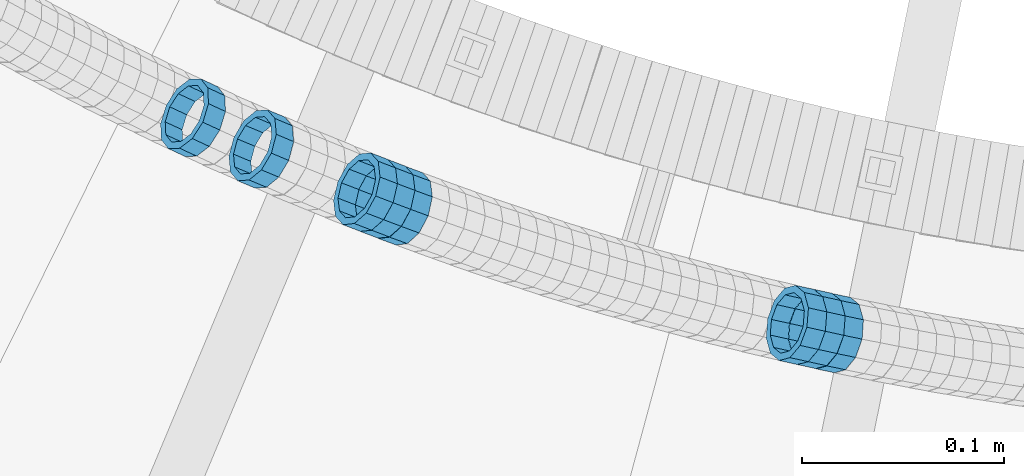
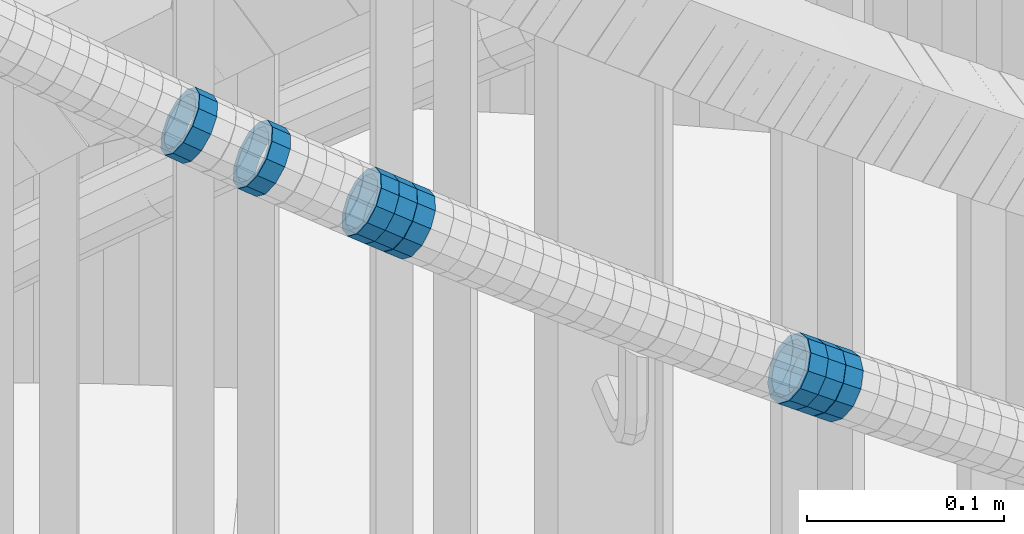
# One storey, part 690 of 975: 8 members.
"""IFC2X3 building model written with IfcOpenShell, lengths in millimetres."""

from ifc_helpers import new_model, si_unit, frame, origin_with_axes, place, context, subcontext, project, spatial, faceted_brep, material, type_object, element, save


model = new_model("IFC2X3")

# Units and contexts
model_context = context("Model", 3, precision=1e-05, world=origin_with_axes())
body_context = subcontext(model_context, "Body", "Model", "MODEL_VIEW")
ifc_project = project(units=[si_unit("LENGTHUNIT", "METRE", prefix="MILLI"), si_unit("AREAUNIT", "SQUARE_METRE"), si_unit("VOLUMEUNIT", "CUBIC_METRE"), si_unit("MASSUNIT", "GRAM", prefix="KILO"), si_unit("TIMEUNIT", "SECOND"), si_unit("PLANEANGLEUNIT", "RADIAN"), si_unit("SOLIDANGLEUNIT", "STERADIAN"), si_unit("THERMODYNAMICTEMPERATUREUNIT", "DEGREE_CELSIUS"), si_unit("LUMINOUSINTENSITYUNIT", "LUMEN")], contexts=[model_context])

# Site, building, storey
site_placement = place(None, origin_with_axes())
site = spatial("IfcSite", under=ifc_project, at=site_placement, CompositionType="ELEMENT")
building_placement = place(site_placement, origin_with_axes())
building = spatial("IfcBuilding", under=site, at=building_placement, Name="Undefined", CompositionType="ELEMENT")
storey_placement = place(building_placement, origin_with_axes())
storey = spatial("IfcBuildingStorey", under=building, at=storey_placement, Name="Undefined", CompositionType="ELEMENT", Elevation=0.0)

# Members
ifc_material = material()
member_type = type_object("IfcMemberType", PredefinedType="NOTDEFINED")
member_1_placement = place(storey_placement, frame((34111.9400703287, 2061.41221521128, 4603.27653014388), z_axis=(-0.421111305950152, -0.907008967982653, -2.33285391004756e-11), x_axis=(-0.772432162974073, 0.358629217987961, 0.524150395982431)))
element("IfcMember", 1, at=member_1_placement, inside=storey, type_object=member_type, material=ifc_material, Name="WALL", context=body_context, shape_type="Brep", body=[
    faceted_brep([(-2.1246523829177e-07, -15.367000000002, 0.0), (-1.83998054126278e-07, -13.3082123799541, 7.68350000000009), (10.8747413762467, -13.3082123799468, 7.68349999999737), (10.8747413762612, -15.3669999999911, -4.54747350886464e-12), (-1.06232619145885e-07, -7.68349999999919, 13.3082123799559), (10.8747413762321, -7.68350000000282, 13.3082123799559), (-3.63797880709171e-12, 3.63797880709171e-12, 15.3670000000002), (10.8747413762212, -7.27595761418343e-12, 15.3670000000029), (1.06225343188271e-07, 7.68350000000646, 13.3082123799559), (10.8747413762139, 7.68349999998827, 13.3082123799586), (1.8399441614747e-07, 13.308212379965, 7.68350000000009), (10.8747413762212, 13.3082123799504, 7.683500000001), (2.12461600312963e-07, 15.3670000000093, 0.0), (10.8747413762285, 15.3669999999984, 9.09494701772928e-13), (1.8399441614747e-07, 13.308212379965, -7.68350000000009), (10.8747413762394, 13.3082123799613, -7.683500000001), (1.06225343188271e-07, 7.68350000000646, -13.3082123799559), (10.874741376254, 7.68350000001374, -13.3082123799604), (-3.63797880709171e-12, 3.63797880709171e-12, -15.3670000000002), (10.8747413762685, 1.81898940354586e-11, -15.3670000000056), (-1.06232619145885e-07, -7.68349999999919, -13.3082123799559), (10.8747413762758, -7.683499999981, -13.3082123799632), (-1.83998054126278e-07, -13.3082123799541, -7.68350000000009), (10.8747413762721, -13.3082123799359, -7.68350000000737), (-2.63386027654633e-07, -19.0500000000029, 0.0), (-2.28097633225843e-07, -16.4977839420972, -9.52499999999964), (10.8747413762867, -16.4977839420681, -9.52500000000873), (10.8747413762685, -19.0499999999847, -6.3664629124105e-12), (-1.31691194837913e-07, -9.52500000000146, -16.4977839420935), (10.8747413762831, -9.52499999997599, -16.4977839421026), (-3.63797880709171e-12, 3.63797880709171e-12, -19.0500000000002), (10.8747413762758, 2.5465851649642e-11, -19.0500000000084), (1.31687556859106e-07, 9.52500000000509, -16.4977839420935), (10.8747413762612, 9.52500000001601, -16.497783942099), (2.28097633225843e-07, 16.4977839421044, -9.52499999999964), (10.8747413762394, 16.4977839421008, -9.52500000000146), (2.63382389675826e-07, 19.0500000000138, 0.0), (10.8747413762248, 19.0499999999956, 0.0), (2.28097633225843e-07, 16.4977839421044, 9.52499999999964), (10.8747413762103, 16.497783942079, 9.52500000000418), (1.31687556859106e-07, 9.52500000000509, 16.4977839420935), (10.8747413762067, 9.52499999998327, 16.4977839420981), (-3.63797880709171e-12, 3.63797880709171e-12, 19.0500000000002), (10.8747413762212, -1.09139364212751e-11, 19.0500000000029), (-1.31691194837913e-07, -9.52500000000146, 16.4977839420935), (10.8747413762358, -9.52500000000146, 16.4977839420944), (-2.28097633225843e-07, -16.4977839420972, 9.52499999999964), (10.874741376254, -16.4977839420862, 9.524999999996)], [[[0, 1, 2, 3]], [[1, 4, 5, 2]], [[4, 6, 7, 5]], [[6, 8, 9, 7]], [[8, 10, 11, 9]], [[10, 12, 13, 11]], [[12, 14, 15, 13]], [[14, 16, 17, 15]], [[16, 18, 19, 17]], [[18, 20, 21, 19]], [[20, 22, 23, 21]], [[22, 0, 3, 23]], [[24, 25, 26, 27]], [[25, 28, 29, 26]], [[28, 30, 31, 29]], [[30, 32, 33, 31]], [[32, 34, 35, 33]], [[34, 36, 37, 35]], [[36, 38, 39, 37]], [[38, 40, 41, 39]], [[40, 42, 43, 41]], [[42, 44, 45, 43]], [[44, 46, 47, 45]], [[46, 24, 27, 47]], [[29, 31, 33, 35, 37, 39, 41, 43, 45, 47, 27, 26], [5, 7, 9, 11, 13, 15, 17, 19, 21, 23, 3, 2]], [[46, 44, 42, 40, 38, 36, 34, 32, 30, 28, 25, 24], [22, 20, 18, 16, 14, 12, 10, 8, 6, 4, 1, 0]]]),
])
member_2_placement = place(storey_placement, frame((34419.763839228, 1957.86844079665, 4402.52752626704), z_axis=(-0.214657030653907, -0.976689489649012, -1.63522599905264e-10), x_axis=(-0.829159326808045, 0.182232818957796, 0.528475174877615)))
element("IfcMember", 2, at=member_2_placement, inside=storey, type_object=member_type, material=ifc_material, Name="WALL", context=body_context, shape_type="Brep", body=[
    faceted_brep([(-2.1246523829177e-07, -15.367000000002, 0.0), (-1.83998054126278e-07, -13.3082123799541, 7.68350000000009), (10.9726933794955, -13.3082123799577, 7.68349999999873), (10.9726933795027, -15.3669999999984, -3.18323145620525e-12), (-1.06232619145885e-07, -7.68349999999919, 13.3082123799559), (10.9726933794846, -7.6835000000101, 13.308212379955), (-3.63797880709171e-12, 3.63797880709171e-12, 15.3670000000002), (10.9726933794773, -1.09139364212751e-11, 15.3670000000011), (1.06225343188271e-07, 7.68350000000646, 13.3082123799559), (10.9726933794773, 7.68349999998827, 13.3082123799563), (1.8399441614747e-07, 13.308212379965, 7.68350000000009), (10.9726933794846, 13.3082123799504, 7.68350000000146), (2.12461600312963e-07, 15.3670000000093, 0.0), (10.9726933794882, 15.3669999999984, 9.09494701772928e-13), (1.8399441614747e-07, 13.308212379965, -7.68350000000009), (10.9726933794955, 13.3082123799613, -7.68350000000055), (1.06225343188271e-07, 7.68350000000646, -13.3082123799559), (10.97269337951, 7.68350000001374, -13.3082123799572), (-3.63797880709171e-12, 3.63797880709171e-12, -15.3670000000002), (10.97269337951, 1.09139364212751e-11, -15.3670000000029), (-1.06232619145885e-07, -7.68349999999919, -13.3082123799559), (10.9726933795137, -7.68349999998463, -13.3082123799586), (-1.83998054126278e-07, -13.3082123799541, -7.68350000000009), (10.9726933795064, -13.3082123799468, -7.68350000000328), (-2.63386027654633e-07, -19.0500000000029, 0.0), (-2.28097633225843e-07, -16.4977839420972, -9.52499999999964), (10.97269337951, -16.4977839420826, -9.52500000000418), (10.9726933795027, -19.0499999999993, -2.27373675443232e-12), (-1.31691194837913e-07, -9.52500000000146, -16.4977839420935), (10.9726933795137, -9.52499999998327, -16.4977839420976), (-3.63797880709171e-12, 3.63797880709171e-12, -19.0500000000002), (10.9726933795209, 1.81898940354586e-11, -19.0500000000034), (1.31687556859106e-07, 9.52500000000509, -16.4977839420935), (10.97269337951, 9.52500000001237, -16.4977839420958), (2.28097633225843e-07, 16.4977839421044, -9.52499999999964), (10.9726933795027, 16.4977839421008, -9.525000000001), (2.63382389675826e-07, 19.0500000000138, 0.0), (10.9726933794882, 19.0499999999993, 4.54747350886464e-13), (2.28097633225843e-07, 16.4977839421044, 9.52499999999964), (10.9726933794809, 16.4977839420826, 9.52500000000236), (1.31687556859106e-07, 9.52500000000509, 16.4977839420935), (10.97269337947, 9.5249999999869, 16.4977839420967), (-3.63797880709171e-12, 3.63797880709171e-12, 19.0500000000002), (10.9726933794736, -1.81898940354586e-11, 19.0500000000015), (-1.31691194837913e-07, -9.52500000000146, 16.4977839420935), (10.9726933794809, -9.52500000001237, 16.4977839420931), (-2.28097633225843e-07, -16.4977839420972, 9.52499999999964), (10.9726933794882, -16.4977839420972, 9.52499999999827)], [[[0, 1, 2, 3]], [[1, 4, 5, 2]], [[4, 6, 7, 5]], [[6, 8, 9, 7]], [[8, 10, 11, 9]], [[10, 12, 13, 11]], [[12, 14, 15, 13]], [[14, 16, 17, 15]], [[16, 18, 19, 17]], [[18, 20, 21, 19]], [[20, 22, 23, 21]], [[22, 0, 3, 23]], [[24, 25, 26, 27]], [[25, 28, 29, 26]], [[28, 30, 31, 29]], [[30, 32, 33, 31]], [[32, 34, 35, 33]], [[34, 36, 37, 35]], [[36, 38, 39, 37]], [[38, 40, 41, 39]], [[40, 42, 43, 41]], [[42, 44, 45, 43]], [[44, 46, 47, 45]], [[46, 24, 27, 47]], [[29, 31, 33, 35, 37, 39, 41, 43, 45, 47, 27, 26], [5, 7, 9, 11, 13, 15, 17, 19, 21, 23, 3, 2]], [[46, 44, 42, 40, 38, 36, 34, 32, 30, 28, 25, 24], [22, 20, 18, 16, 14, 12, 10, 8, 6, 4, 1, 0]]]),
])
member_3_placement = place(storey_placement, frame((34428.9490765305, 1955.84259152865, 4396.75974216532), z_axis=(-0.204383799684052, -0.978890832742196, -1.57330759975593e-10), x_axis=(-0.834511263849983, 0.174238614968701, 0.522715845906064)))
element("IfcMember", 3, at=member_3_placement, inside=storey, type_object=member_type, material=ifc_material, Name="WALL", context=body_context, shape_type="Brep", body=[
    faceted_brep([(-2.1246523829177e-07, -15.367000000002, 0.0), (-1.83998054126278e-07, -13.3082123799541, 7.68350000000009), (10.9004587059244, -13.3082123799686, 7.68350000000282), (10.9004587059426, -15.3670000000093, 9.09494701772928e-13), (-1.06232619145885e-07, -7.68349999999919, 13.3082123799559), (10.9004587059244, -7.68350000001737, 13.3082123799586), (-3.63797880709171e-12, 3.63797880709171e-12, 15.3670000000002), (10.9004587059353, -1.45519152283669e-11, 15.3670000000029), (1.06225343188271e-07, 7.68350000000646, 13.3082123799559), (10.9004587059571, 7.68349999999555, 13.308212379955), (1.8399441614747e-07, 13.308212379965, 7.68350000000009), (10.9004587059753, 13.308212379965, 7.68349999999691), (2.12461600312963e-07, 15.3670000000093, 0.0), (10.9004587059935, 15.3670000000202, -5.45696821063757e-12), (1.8399441614747e-07, 13.308212379965, -7.68350000000009), (10.9004587060081, 13.3082123799832, -7.68350000000737), (1.06225343188271e-07, 7.68350000000646, -13.3082123799559), (10.9004587060081, 7.68350000002829, -13.3082123799632), (-3.63797880709171e-12, 3.63797880709171e-12, -15.3670000000002), (10.9004587060008, 2.91038304567337e-11, -15.3670000000075), (-1.06232619145885e-07, -7.68349999999919, -13.3082123799559), (10.900458705979, -7.683499999981, -13.3082123799595), (-1.83998054126278e-07, -13.3082123799541, -7.68350000000009), (10.9004587059608, -13.3082123799504, -7.68350000000191), (-2.63386027654633e-07, -19.0500000000029, 0.0), (-2.28097633225843e-07, -16.4977839420972, -9.52499999999964), (10.9004587059499, -16.4977839420899, -9.525000000001), (10.9004587059317, -19.0500000000102, 1.81898940354586e-12), (-1.31691194837913e-07, -9.52500000000146, -16.4977839420935), (10.9004587059826, -9.52499999997963, -16.497783942099), (-3.63797880709171e-12, 3.63797880709171e-12, -19.0500000000002), (10.9004587060008, 2.91038304567337e-11, -19.0500000000084), (1.31687556859106e-07, 9.52500000000509, -16.4977839420935), (10.900458706019, 9.52500000003783, -16.4977839421026), (2.28097633225843e-07, 16.4977839421044, -9.52499999999964), (10.900458706019, 16.4977839421263, -9.52500000000873), (2.63382389675826e-07, 19.0500000000138, 0.0), (10.9004587060044, 19.0500000000247, -6.82121026329696e-12), (2.28097633225843e-07, 16.4977839421044, 9.52499999999964), (10.9004587059826, 16.4977839421044, 9.52499999999736), (1.31687556859106e-07, 9.52500000000509, 16.4977839420935), (10.9004587059571, 9.52499999999418, 16.497783942094), (-3.63797880709171e-12, 3.63797880709171e-12, 19.0500000000002), (10.900458705928, -2.18278728425503e-11, 19.0500000000038), (-1.31691194837913e-07, -9.52500000000146, 16.4977839420935), (10.9004587059135, -9.52500000002328, 16.4977839420981), (-2.28097633225843e-07, -16.4977839420972, 9.52499999999964), (10.9004587059171, -16.4977839421153, 9.52500000000373)], [[[0, 1, 2, 3]], [[1, 4, 5, 2]], [[4, 6, 7, 5]], [[6, 8, 9, 7]], [[8, 10, 11, 9]], [[10, 12, 13, 11]], [[12, 14, 15, 13]], [[14, 16, 17, 15]], [[16, 18, 19, 17]], [[18, 20, 21, 19]], [[20, 22, 23, 21]], [[22, 0, 3, 23]], [[24, 25, 26, 27]], [[25, 28, 29, 26]], [[28, 30, 31, 29]], [[30, 32, 33, 31]], [[32, 34, 35, 33]], [[34, 36, 37, 35]], [[36, 38, 39, 37]], [[38, 40, 41, 39]], [[40, 42, 43, 41]], [[42, 44, 45, 43]], [[44, 46, 47, 45]], [[46, 24, 27, 47]], [[29, 31, 33, 35, 37, 39, 41, 43, 45, 47, 27, 26], [5, 7, 9, 11, 13, 15, 17, 19, 21, 23, 3, 2]], [[46, 44, 42, 40, 38, 36, 34, 32, 30, 28, 25, 24], [22, 20, 18, 16, 14, 12, 10, 8, 6, 4, 1, 0]]]),
])
member_4_placement = place(storey_placement, frame((34410.7869067973, 1959.84139297923, 4408.24976541374), z_axis=(-0.214657030653907, -0.976689489649012, -1.63522599905264e-10), x_axis=(-0.833146108987075, 0.183109034997161, 0.521860749991897)))
element("IfcMember", 4, at=member_4_placement, inside=storey, type_object=member_type, material=ifc_material, Name="WALL", context=body_context, shape_type="Brep", body=[
    faceted_brep([(-2.1246523829177e-07, -15.367000000002, 0.0), (-1.83998054126278e-07, -13.3082123799541, 7.68350000000009), (10.9242848735521, -13.3082123800159, 7.68350000000919), (10.9242848735703, -15.3670000000457, 6.82121026329696e-12), (-1.06232619145885e-07, -7.68349999999919, 13.3082123799559), (10.9242848735521, -7.68350000005739, 13.3082123799652), (-3.63797880709171e-12, 3.63797880709171e-12, 15.3670000000002), (10.924284873563, -4.72937244921923e-11, 15.3670000000088), (1.06225343188271e-07, 7.68350000000646, 13.3082123799559), (10.9242848735885, 7.68349999997008, 13.308212379962), (1.8399441614747e-07, 13.308212379965, 7.68350000000009), (10.9242848736176, 13.3082123799468, 7.68350000000328), (2.12461600312963e-07, 15.3670000000093, 0.0), (10.9242848736394, 15.3670000000093, 0.0), (1.8399441614747e-07, 13.308212379965, -7.68350000000009), (10.9242848736576, 13.3082123799795, -7.6835000000026), (1.06225343188271e-07, 7.68350000000646, -13.3082123799559), (10.9242848736576, 7.68350000002465, -13.3082123799584), (-3.63797880709171e-12, 3.63797880709171e-12, -15.3670000000002), (10.9242848736467, 1.45519152283669e-11, -15.3670000000025), (-1.06232619145885e-07, -7.68349999999919, -13.3082123799559), (10.9242848736212, -7.68350000000282, -13.3082123799552), (-1.83998054126278e-07, -13.3082123799541, -7.68350000000009), (10.9242848735958, -13.3082123799832, -7.68349999999646), (-2.63386027654633e-07, -19.0500000000029, 0.0), (-2.28097633225843e-07, -16.4977839420972, -9.52499999999964), (10.9242848735885, -16.4977839421226, -9.52499999999577), (10.9242848735557, -19.0500000000575, 8.18545231595635e-12), (-1.31691194837913e-07, -9.52500000000146, -16.4977839420935), (10.9242848736249, -9.52500000000146, -16.4977839420942), (-3.63797880709171e-12, 3.63797880709171e-12, -19.0500000000002), (10.924284873654, 2.18278728425503e-11, -19.0500000000038), (1.31687556859106e-07, 9.52500000000509, -16.4977839420935), (10.9242848736758, 9.52500000003783, -16.4977839420985), (2.28097633225843e-07, 16.4977839421044, -9.52499999999964), (10.9242848736758, 16.4977839421299, -9.52500000000418), (2.63382389675826e-07, 19.0500000000138, 0.0), (10.9242848736503, 19.0500000000211, -1.36424205265939e-12), (2.28097633225843e-07, 16.4977839421044, 9.52499999999964), (10.9242848736249, 16.4977839420899, 9.52500000000259), (1.31687556859106e-07, 9.52500000000509, 16.4977839420935), (10.9242848735885, 9.52499999996508, 16.4977839421008), (-3.63797880709171e-12, 3.63797880709171e-12, 19.0500000000002), (10.9242848735594, -5.82076609134674e-11, 19.0500000000104), (-1.31691194837913e-07, -9.52500000000146, 16.4977839420935), (10.9242848735375, -9.52500000007058, 16.4977839421056), (-2.28097633225843e-07, -16.4977839420972, 9.52499999999964), (10.9242848735412, -16.4977839421626, 9.52500000001078)], [[[0, 1, 2, 3]], [[1, 4, 5, 2]], [[4, 6, 7, 5]], [[6, 8, 9, 7]], [[8, 10, 11, 9]], [[10, 12, 13, 11]], [[12, 14, 15, 13]], [[14, 16, 17, 15]], [[16, 18, 19, 17]], [[18, 20, 21, 19]], [[20, 22, 23, 21]], [[22, 0, 3, 23]], [[24, 25, 26, 27]], [[25, 28, 29, 26]], [[28, 30, 31, 29]], [[30, 32, 33, 31]], [[32, 34, 35, 33]], [[34, 36, 37, 35]], [[36, 38, 39, 37]], [[38, 40, 41, 39]], [[40, 42, 43, 41]], [[42, 44, 45, 43]], [[44, 46, 47, 45]], [[46, 24, 27, 47]], [[29, 31, 33, 35, 37, 39, 41, 43, 45, 47, 27, 26], [5, 7, 9, 11, 13, 15, 17, 19, 21, 23, 3, 2]], [[46, 44, 42, 40, 38, 36, 34, 32, 30, 28, 25, 24], [22, 20, 18, 16, 14, 12, 10, 8, 6, 4, 1, 0]]]),
])
member_5_placement = place(storey_placement, frame((34145.8142209841, 2046.09304426026, 4580.32466746783), z_axis=(-0.386138087857282, -0.922440988413851, -1.81316863745451e-10), x_axis=(-0.783243558288826, 0.327869396120886, 0.528234027194749)))
element("IfcMember", 5, at=member_5_placement, inside=storey, type_object=member_type, material=ifc_material, Name="WALL", context=body_context, shape_type="Brep", body=[
    faceted_brep([(-2.1246523829177e-07, -15.367000000002, 0.0), (-1.83998054126278e-07, -13.3082123799541, 7.68350000000009), (10.9799817850508, -13.3082123799686, 7.6835000000051), (10.9799817850435, -15.3670000000202, 5.45696821063757e-12), (-1.06232619145885e-07, -7.68349999999919, 13.3082123799559), (10.9799817850653, -7.68350000000282, 13.3082123799577), (-3.63797880709171e-12, 3.63797880709171e-12, 15.3670000000002), (10.9799817850871, 1.45519152283669e-11, 15.3669999999984), (1.06225343188271e-07, 7.68350000000646, 13.3082123799559), (10.9799817851053, 7.68350000002465, 13.3082123799504), (1.8399441614747e-07, 13.308212379965, 7.68350000000009), (10.9799817851163, 13.3082123799904, 7.68349999999191), (2.12461600312963e-07, 15.3670000000093, 0.0), (10.9799817851199, 15.3670000000347, -9.09494701772928e-12), (1.8399441614747e-07, 13.308212379965, -7.68350000000009), (10.9799817851126, 13.3082123799832, -7.68350000000783), (1.06225343188271e-07, 7.68350000000646, -13.3082123799559), (10.9799817850981, 7.68350000001737, -13.3082123799613), (-3.63797880709171e-12, 3.63797880709171e-12, -15.3670000000002), (10.9799817850799, 3.63797880709171e-12, -15.367000000002), (-1.06232619145885e-07, -7.68349999999919, -13.3082123799559), (10.9799817850653, -7.68350000000646, -13.308212379955), (-1.83998054126278e-07, -13.3082123799541, -7.68350000000009), (10.9799817850508, -13.3082123799722, -7.68349999999509), (-2.63386027654633e-07, -19.0500000000029, 0.0), (-2.28097633225843e-07, -16.4977839420972, -9.52499999999964), (10.9799817850399, -16.4977839421153, -9.52499999999418), (10.9799817850362, -19.0500000000247, 6.3664629124105e-12), (-1.31691194837913e-07, -9.52500000000146, -16.4977839420935), (10.979981785058, -9.52500000001237, -16.4977839420912), (-3.63797880709171e-12, 3.63797880709171e-12, -19.0500000000002), (10.9799817850799, 0.0, -19.050000000002), (1.31687556859106e-07, 9.52500000000509, -16.4977839420935), (10.9799817851017, 9.52500000001965, -16.4977839420999), (2.28097633225843e-07, 16.4977839421044, -9.52499999999964), (10.9799817851235, 16.4977839421299, -9.5250000000101), (2.63382389675826e-07, 19.0500000000138, 0.0), (10.9799817851308, 19.0500000000393, -1.09139364212751e-11), (2.28097633225843e-07, 16.4977839421044, 9.52499999999964), (10.9799817851235, 16.4977839421335, 9.52499999999054), (1.31687556859106e-07, 9.52500000000509, 16.4977839420935), (10.979981785109, 9.52500000003056, 16.4977839420881), (-3.63797880709171e-12, 3.63797880709171e-12, 19.0500000000002), (10.9799817850871, 1.45519152283669e-11, 19.0499999999984), (-1.31691194837913e-07, -9.52500000000146, 16.4977839420935), (10.9799817850617, -9.52500000000509, 16.4977839420962), (-2.28097633225843e-07, -16.4977839420972, 9.52499999999964), (10.9799817850435, -16.4977839421117, 9.52500000000691)], [[[0, 1, 2, 3]], [[1, 4, 5, 2]], [[4, 6, 7, 5]], [[6, 8, 9, 7]], [[8, 10, 11, 9]], [[10, 12, 13, 11]], [[12, 14, 15, 13]], [[14, 16, 17, 15]], [[16, 18, 19, 17]], [[18, 20, 21, 19]], [[20, 22, 23, 21]], [[22, 0, 3, 23]], [[24, 25, 26, 27]], [[25, 28, 29, 26]], [[28, 30, 31, 29]], [[30, 32, 33, 31]], [[32, 34, 35, 33]], [[34, 36, 37, 35]], [[36, 38, 39, 37]], [[38, 40, 41, 39]], [[40, 42, 43, 41]], [[42, 44, 45, 43]], [[44, 46, 47, 45]], [[46, 24, 27, 47]], [[29, 31, 33, 35, 37, 39, 41, 43, 45, 47, 27, 26], [5, 7, 9, 11, 13, 15, 17, 19, 21, 23, 3, 2]], [[46, 44, 42, 40, 38, 36, 34, 32, 30, 28, 25, 24], [22, 20, 18, 16, 14, 12, 10, 8, 6, 4, 1, 0]]]),
])
member_6_placement = place(storey_placement, frame((34214.7316920949, 2018.25196035321, 4534.47237900324), z_axis=(-0.345205393572717, -0.938527163298061, 2.67247742158361e-10), x_axis=(-0.799478380651726, 0.294061013871895, 0.523796180771803)))
element("IfcMember", 6, at=member_6_placement, inside=storey, type_object=member_type, material=ifc_material, Name="WALL", context=body_context, shape_type="Brep", body=[
    faceted_brep([(-2.1246523829177e-07, -15.367000000002, 0.0), (-1.83998054126278e-07, -13.3082123799541, 7.68350000000009), (10.8784190028109, -13.3082123799541, 7.68349999999555), (10.8784190028309, -15.3669999999929, 2.5465851649642e-11), (-1.06232619145885e-07, -7.68349999999919, 13.3082123799559), (10.8784190027873, -7.68350000000464, 13.308212379925), (-3.63797880709171e-12, 3.63797880709171e-12, 15.3670000000002), (10.8784190027782, -9.09494701772928e-12, 15.3669999999584), (1.06225343188271e-07, 7.68350000000646, 13.3082123799559), (10.8784190027691, 7.68349999998645, 13.3082123798995), (1.8399441614747e-07, 13.308212379965, 7.68350000000009), (10.8784190027764, 13.3082123799431, 7.68349999995553), (2.12461600312963e-07, 15.3670000000093, 0.0), (10.8784190027891, 15.3669999999929, -2.91038304567337e-11), (1.8399441614747e-07, 13.308212379965, -7.68350000000009), (10.8784190028055, 13.3082123799541, -7.68350000000646), (1.06225343188271e-07, 7.68350000000646, -13.3082123799559), (10.8784190028236, 7.68350000000464, -13.3082123799431), (-3.63797880709171e-12, 3.63797880709171e-12, -15.3670000000002), (10.87841900284, 1.2732925824821e-11, -15.366999999962), (-1.06232619145885e-07, -7.68349999999919, -13.3082123799559), (10.8784190028437, -7.68349999998463, -13.308212379914), (-1.83998054126278e-07, -13.3082123799541, -7.68350000000009), (10.8784190028437, -13.3082123799413, -7.68349999996281), (-2.63386027654633e-07, -19.0500000000029, 0.0), (-2.28097633225843e-07, -16.4977839420972, -9.52499999999964), (10.8784190028491, -16.4977839420771, -9.52499999995416), (10.8784190028346, -19.0499999999902, 2.91038304567337e-11), (-1.31691194837913e-07, -9.52500000000146, -16.4977839420935), (10.8784190028582, -9.52499999998145, -16.497783942039), (-3.63797880709171e-12, 3.63797880709171e-12, -19.0500000000002), (10.8784190028473, 1.63709046319127e-11, -19.0499999999556), (1.31687556859106e-07, 9.52500000000509, -16.4977839420935), (10.8784190028291, 9.52500000000691, -16.4977839420753), (2.28097633225843e-07, 16.4977839421044, -9.52499999999964), (10.8784190028073, 16.4977839420917, -9.52500000000509), (2.63382389675826e-07, 19.0500000000138, 0.0), (10.8784190027836, 19.0499999999884, -4.00177668780088e-11), (2.28097633225843e-07, 16.4977839421044, 9.52499999999964), (10.8784190027654, 16.4977839420771, 9.52499999994325), (1.31687556859106e-07, 9.52500000000509, 16.4977839420935), (10.8784190027636, 9.52499999998327, 16.4977839420317), (-3.63797880709171e-12, 3.63797880709171e-12, 19.0500000000002), (10.8784190027709, -1.63709046319127e-11, 19.0499999999447), (-1.31691194837913e-07, -9.52500000000146, 16.4977839420935), (10.8784190027854, -9.52500000000691, 16.4977839420644), (-2.28097633225843e-07, -16.4977839420972, 9.52499999999964), (10.8784190028091, -16.4977839420899, 9.52500000000146)], [[[0, 1, 2, 3]], [[1, 4, 5, 2]], [[4, 6, 7, 5]], [[6, 8, 9, 7]], [[8, 10, 11, 9]], [[10, 12, 13, 11]], [[12, 14, 15, 13]], [[14, 16, 17, 15]], [[16, 18, 19, 17]], [[18, 20, 21, 19]], [[20, 22, 23, 21]], [[22, 0, 3, 23]], [[24, 25, 26, 27]], [[25, 28, 29, 26]], [[28, 30, 31, 29]], [[30, 32, 33, 31]], [[32, 34, 35, 33]], [[34, 36, 37, 35]], [[36, 38, 39, 37]], [[38, 40, 41, 39]], [[40, 42, 43, 41]], [[42, 44, 45, 43]], [[44, 46, 47, 45]], [[46, 24, 27, 47]], [[29, 31, 33, 35, 37, 39, 41, 43, 45, 47, 27, 26], [5, 7, 9, 11, 13, 15, 17, 19, 21, 23, 3, 2]], [[46, 44, 42, 40, 38, 36, 34, 32, 30, 28, 25, 24], [22, 20, 18, 16, 14, 12, 10, 8, 6, 4, 1, 0]]]),
])
member_7_placement = place(storey_placement, frame((34205.9745710488, 2021.58126973591, 4540.23352230477), z_axis=(-0.35465423399266, -0.934997526366289, -8.52551238494924e-11), x_axis=(-0.793470693350745, 0.300971642133083, 0.528980462233913)))
element("IfcMember", 7, at=member_7_placement, inside=storey, type_object=member_type, material=ifc_material, Name="WALL", context=body_context, shape_type="Brep", body=[
    faceted_brep([(-2.1246523829177e-07, -15.367000000002, 0.0), (-1.83998054126278e-07, -13.3082123799541, 7.68350000000009), (10.9608393839299, -13.3082123799613, 7.68350000000282), (10.9608393839189, -15.3670000000093, 3.63797880709171e-12), (-1.06232619145885e-07, -7.68349999999919, 13.3082123799559), (10.9608393839408, -7.68349999999919, 13.3082123799563), (-3.63797880709171e-12, 3.63797880709171e-12, 15.3670000000002), (10.9608393839517, 3.63797880709171e-12, 15.3669999999993), (1.06225343188271e-07, 7.68350000000646, 13.3082123799559), (10.960839383959, 7.68350000000282, 13.3082123799536), (1.8399441614747e-07, 13.308212379965, 7.68350000000009), (10.9608393839553, 13.3082123799577, 7.68349999999782), (2.12461600312963e-07, 15.3670000000093, 0.0), (10.960839383959, 15.367000000002, -2.27373675443232e-12), (1.8399441614747e-07, 13.308212379965, -7.68350000000009), (10.960839383948, 13.3082123799468, -7.68350000000146), (1.06225343188271e-07, 7.68350000000646, -13.3082123799559), (10.9608393839408, 7.68349999998827, -13.3082123799563), (-3.63797880709171e-12, 3.63797880709171e-12, -15.3670000000002), (10.9608393839299, -1.09139364212751e-11, -15.3669999999993), (-1.06232619145885e-07, -7.68349999999919, -13.3082123799559), (10.9608393839226, -7.68350000001374, -13.3082123799531), (-1.83998054126278e-07, -13.3082123799541, -7.68350000000009), (10.9608393839226, -13.308212379965, -7.68349999999691), (-2.63386027654633e-07, -19.0500000000029, 0.0), (-2.28097633225843e-07, -16.4977839420972, -9.52499999999964), (10.9608393839153, -16.4977839421081, -9.52499999999645), (10.9608393839153, -19.0500000000065, 4.09272615797818e-12), (-1.31691194837913e-07, -9.52500000000146, -16.4977839420935), (10.9608393839189, -9.52500000001237, -16.4977839420908), (-3.63797880709171e-12, 3.63797880709171e-12, -19.0500000000002), (10.9608393839262, -1.45519152283669e-11, -19.0499999999984), (1.31687556859106e-07, 9.52500000000509, -16.4977839420935), (10.9608393839371, 9.5249999999869, -16.4977839420935), (2.28097633225843e-07, 16.4977839421044, -9.52499999999964), (10.9608393839553, 16.4977839420899, -9.52500000000282), (2.63382389675826e-07, 19.0500000000138, 0.0), (10.9608393839626, 19.0499999999993, -3.18323145620525e-12), (2.28097633225843e-07, 16.4977839421044, 9.52499999999964), (10.9608393839626, 16.4977839420972, 9.52499999999645), (1.31687556859106e-07, 9.52500000000509, 16.4977839420935), (10.960839383959, 9.52500000000509, 16.4977839420917), (-3.63797880709171e-12, 3.63797880709171e-12, 19.0500000000002), (10.9608393839517, 7.27595761418343e-12, 19.0499999999997), (-1.31691194837913e-07, -9.52500000000146, 16.4977839420935), (10.9608393839408, -9.52499999999782, 16.4977839420944), (-2.28097633225843e-07, -16.4977839420972, 9.52499999999964), (10.9608393839226, -16.4977839420972, 9.52500000000418)], [[[0, 1, 2, 3]], [[1, 4, 5, 2]], [[4, 6, 7, 5]], [[6, 8, 9, 7]], [[8, 10, 11, 9]], [[10, 12, 13, 11]], [[12, 14, 15, 13]], [[14, 16, 17, 15]], [[16, 18, 19, 17]], [[18, 20, 21, 19]], [[20, 22, 23, 21]], [[22, 0, 3, 23]], [[24, 25, 26, 27]], [[25, 28, 29, 26]], [[28, 30, 31, 29]], [[30, 32, 33, 31]], [[32, 34, 35, 33]], [[34, 36, 37, 35]], [[36, 38, 39, 37]], [[38, 40, 41, 39]], [[40, 42, 43, 41]], [[42, 44, 45, 43]], [[44, 46, 47, 45]], [[46, 24, 27, 47]], [[29, 31, 33, 35, 37, 39, 41, 43, 45, 47, 27, 26], [5, 7, 9, 11, 13, 15, 17, 19, 21, 23, 3, 2]], [[46, 44, 42, 40, 38, 36, 34, 32, 30, 28, 25, 24], [22, 20, 18, 16, 14, 12, 10, 8, 6, 4, 1, 0]]]),
])
member_8_placement = place(storey_placement, frame((34197.3378320724, 2024.89855188164, 4546.00063988883), z_axis=(-0.358251499355807, -0.933625119204339, 1.60260242410004e-10), x_axis=(-0.793917562812218, 0.304642785927939, 0.526201174875515)))
element("IfcMember", 8, at=member_8_placement, inside=storey, type_object=member_type, material=ifc_material, Name="WALL", context=body_context, shape_type="Brep", body=[
    faceted_brep([(-2.1246523829177e-07, -15.367000000002, 0.0), (-1.83998054126278e-07, -13.3082123799541, 7.68350000000009), (10.8323589305219, -13.308212379965, 7.68349999999373), (10.8323589305146, -15.3670000000129, -7.27595761418343e-12), (-1.06232619145885e-07, -7.68349999999919, 13.3082123799559), (10.8323589305437, -7.68349999999919, 13.3082123799531), (-3.63797880709171e-12, 3.63797880709171e-12, 15.3670000000002), (10.8323589305655, 7.27595761418343e-12, 15.367000000002), (1.06225343188271e-07, 7.68350000000646, 13.3082123799559), (10.8323589305764, 7.6835000000101, 13.3082123799604), (1.8399441614747e-07, 13.308212379965, 7.68350000000009), (10.8323589305837, 13.3082123799722, 7.68350000000646), (2.12461600312963e-07, 15.3670000000093, 0.0), (10.8323589305801, 15.3670000000202, 6.3664629124105e-12), (1.8399441614747e-07, 13.308212379965, -7.68350000000009), (10.8323589305692, 13.3082123799722, -7.68349999999555), (1.06225343188271e-07, 7.68350000000646, -13.3082123799559), (10.832358930551, 7.68350000000646, -13.3082123799541), (-3.63797880709171e-12, 3.63797880709171e-12, -15.3670000000002), (10.8323589305328, 0.0, -15.3670000000029), (-1.06232619145885e-07, -7.68349999999919, -13.3082123799559), (10.8323589305182, -7.68350000000646, -13.3082123799604), (-1.83998054126278e-07, -13.3082123799541, -7.68350000000009), (10.8323589305146, -13.3082123799686, -7.68350000000737), (-2.63386027654633e-07, -19.0500000000029, 0.0), (-2.28097633225843e-07, -16.4977839420972, -9.52499999999964), (10.8323589305, -16.4977839421117, -9.52500000000873), (10.832358930511, -19.0500000000102, -9.09494701772928e-12), (-1.31691194837913e-07, -9.52500000000146, -16.4977839420935), (10.8323589305146, -9.52500000000873, -16.4977839420999), (-3.63797880709171e-12, 3.63797880709171e-12, -19.0500000000002), (10.8323589305328, 3.63797880709171e-12, -19.0500000000029), (1.31687556859106e-07, 9.52500000000509, -16.4977839420935), (10.8323589305546, 9.52500000000873, -16.4977839420917), (2.28097633225843e-07, 16.4977839421044, -9.52499999999964), (10.8323589305764, 16.4977839421117, -9.52499999999327), (2.63382389675826e-07, 19.0500000000138, 0.0), (10.8323589305874, 19.0500000000211, 8.18545231595635e-12), (2.28097633225843e-07, 16.4977839421044, 9.52499999999964), (10.832358930591, 16.4977839421153, 9.52500000000873), (1.31687556859106e-07, 9.52500000000509, 16.4977839420935), (10.8323589305837, 9.52500000001601, 16.4977839420999), (-3.63797880709171e-12, 3.63797880709171e-12, 19.0500000000002), (10.8323589305619, 7.27595761418343e-12, 19.0500000000011), (-1.31691194837913e-07, -9.52500000000146, 16.4977839420935), (10.8323589305401, -9.52500000000146, 16.4977839420908), (-2.28097633225843e-07, -16.4977839420972, 9.52499999999964), (10.8323589305219, -16.4977839421044, 9.52499999999236)], [[[0, 1, 2, 3]], [[1, 4, 5, 2]], [[4, 6, 7, 5]], [[6, 8, 9, 7]], [[8, 10, 11, 9]], [[10, 12, 13, 11]], [[12, 14, 15, 13]], [[14, 16, 17, 15]], [[16, 18, 19, 17]], [[18, 20, 21, 19]], [[20, 22, 23, 21]], [[22, 0, 3, 23]], [[24, 25, 26, 27]], [[25, 28, 29, 26]], [[28, 30, 31, 29]], [[30, 32, 33, 31]], [[32, 34, 35, 33]], [[34, 36, 37, 35]], [[36, 38, 39, 37]], [[38, 40, 41, 39]], [[40, 42, 43, 41]], [[42, 44, 45, 43]], [[44, 46, 47, 45]], [[46, 24, 27, 47]], [[29, 31, 33, 35, 37, 39, 41, 43, 45, 47, 27, 26], [5, 7, 9, 11, 13, 15, 17, 19, 21, 23, 3, 2]], [[46, 44, 42, 40, 38, 36, 34, 32, 30, 28, 25, 24], [22, 20, 18, 16, 14, 12, 10, 8, 6, 4, 1, 0]]]),
])

save(model, "model.ifc")
